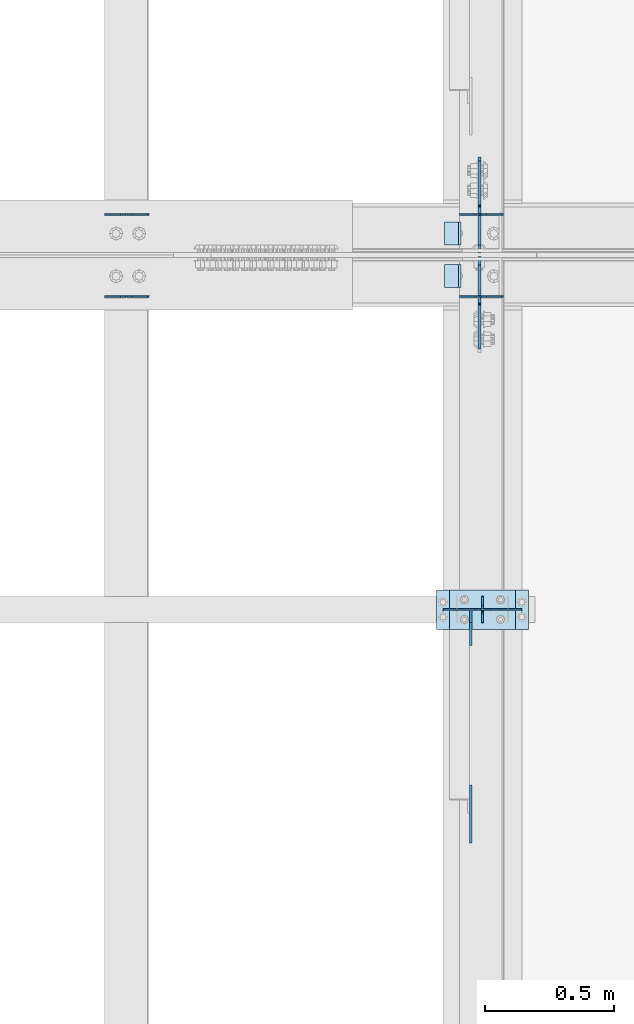
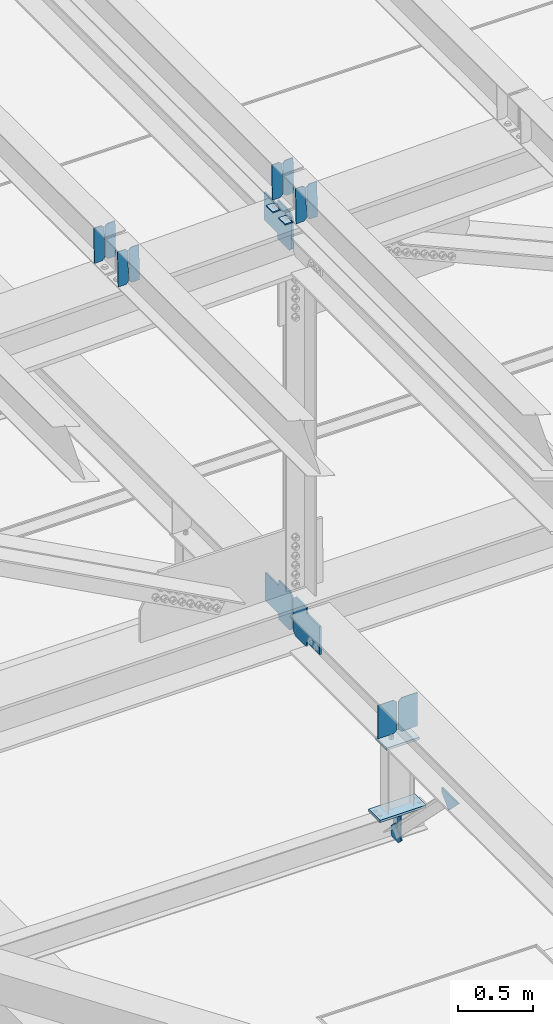
# One storey, part 3239 of 3843: 21 plates, 9 elements without a shape of their own.
"""IFC2X3 building model written with IfcOpenShell, lengths in millimetres."""

from ifc_helpers import new_model, si_unit, frame, origin_with_axes, place, context, subcontext, project, spatial, faceted_brep, material, type_object, element, aggregate, save


model = new_model("IFC2X3")

# Units and contexts
model_context = context("Model", 3, precision=1e-05, world=origin_with_axes())
body_context = subcontext(model_context, "Body", "Model", "MODEL_VIEW")
ifc_project = project(units=[si_unit("LENGTHUNIT", "METRE", prefix="MILLI"), si_unit("AREAUNIT", "SQUARE_METRE"), si_unit("VOLUMEUNIT", "CUBIC_METRE"), si_unit("MASSUNIT", "GRAM", prefix="KILO"), si_unit("TIMEUNIT", "SECOND"), si_unit("PLANEANGLEUNIT", "RADIAN"), si_unit("SOLIDANGLEUNIT", "STERADIAN"), si_unit("THERMODYNAMICTEMPERATUREUNIT", "DEGREE_CELSIUS"), si_unit("LUMINOUSINTENSITYUNIT", "LUMEN")], contexts=[model_context])

# Site, building, storey
site_placement = place(None, origin_with_axes())
site = spatial("IfcSite", under=ifc_project, at=site_placement, CompositionType="ELEMENT")
building_placement = place(site_placement, origin_with_axes())
building = spatial("IfcBuilding", under=site, at=building_placement, Name="Undefined", CompositionType="ELEMENT")
storey_placement = place(building_placement, origin_with_axes())
storey = spatial("IfcBuildingStorey", under=building, at=storey_placement, Name="Undefined", CompositionType="ELEMENT", Elevation=0.0)

# Assembly, plates
assembly_1_placement = place(storey_placement, origin_with_axes())
assembly_1 = element("IfcElementAssembly", 1, at=assembly_1_placement, inside=storey, Name="BEAM", AssemblyPlace="NOTDEFINED", PredefinedType="RIGID_FRAME")
ifc_material = material(Name="STEEL/A572-50")
plate_type_1 = type_object("IfcPlateType", PredefinedType="NOTDEFINED")
plate_1_placement = place(assembly_1_placement, frame((42144.6964783411, 42357.8352138317, 45573.5122364261), z_axis=(-0.021152098061597, -0.00053725799998938, 0.999776124990707), x_axis=(-0.999776269355722, 1.23390000256453e-05, -0.0211520940075457)))
plate_1 = element("IfcPlate", 2, at=plate_1_placement, type_object=plate_type_1, material=ifc_material, Name="PLATE", context=body_context, shape_type="Brep", body=[
    faceted_brep([(0.0, -3.17499999999927, 0.0), (6.83940015733242e-10, -3.17499999996653, 288.924999998613), (6.54836185276508e-10, 3.17500000001746, 288.924999998591), (0.0, 3.17499999999927, 0.0), (60.3250007643655, -3.17500000017753, 288.924999998606), (60.3250007643219, 3.17499999979918, 288.924999998584), (79.3750000013097, -3.17500000025029, 269.875000761494), (79.375000001266, 3.17499999972642, 269.875000761487), (79.375000000713, -3.17500000026484, 19.0499992370605), (79.3750000006985, 3.17499999971187, 19.0499992370533), (60.325000763667, -3.17500000020664, -1.45519152283669e-11), (60.3250007636234, 3.17499999977736, -3.63797880709171e-11)], [[[0, 1, 2, 3]], [[1, 4, 5, 2]], [[4, 6, 7, 5]], [[6, 8, 9, 7]], [[8, 10, 11, 9]], [[10, 0, 3, 11]], [[5, 7, 9, 11, 3, 2]], [[10, 8, 6, 4, 1, 0]]]),
])
plate_2_placement = place(assembly_1_placement, frame((42058.9906576515, 42357.8361882393, 45571.6989730871), z_axis=(-0.021152098061597, -0.00053725799998938, 0.999776124990707), x_axis=(-0.999776269355722, 1.23390000256453e-05, -0.0211520940075457)))
plate_2 = element("IfcPlate", 3, at=plate_2_placement, type_object=plate_type_1, material=ifc_material, Name="PLATE", context=body_context, shape_type="Brep", body=[
    faceted_brep([(4.36557456851006e-11, -3.17499999998836, 19.0499992370969), (6.11180439591408e-10, -3.17499999996653, 269.875000761516), (5.96628524363041e-10, 3.17500000001746, 269.875000761502), (1.45519152283669e-11, 3.17499999998836, 19.0499992370824), (19.0499992376572, -3.17500000003201, 288.924999998606), (19.0499992376281, 3.1749999999447, 288.924999998584), (79.3750000013242, -3.17500000025029, 288.924999998591), (79.3750000013097, 3.1749999997337, 288.92499999857), (79.3750000006548, -3.17500000026484, -2.18278728425503e-11), (79.3750000006403, 3.17499999969732, -2.91038304567337e-11), (19.0499992370023, -3.17500000005384, 0.0), (19.0499992369587, 3.17499999992287, -1.45519152283669e-11)], [[[0, 1, 2, 3]], [[1, 4, 5, 2]], [[4, 6, 7, 5]], [[6, 8, 9, 7]], [[8, 10, 11, 9]], [[10, 0, 3, 11]], [[5, 7, 9, 11, 3, 2]], [[10, 8, 6, 4, 1, 0]]]),
])

assembly_2_placement = place(storey_placement, origin_with_axes())
assembly_2 = element("IfcElementAssembly", 4, at=assembly_2_placement, inside=storey, Name="BEAM", AssemblyPlace="NOTDEFINED", PredefinedType="RIGID_FRAME")
plate_3_placement = place(assembly_2_placement, frame((42144.6964783497, 42041.0140349035, 45572.9760677452), z_axis=(-0.0211520984707749, -0.0028085760011163, 0.999772324397474), x_axis=(-0.999776269337437, 5.94210000636336e-05, -0.0211520150071355)))
plate_3 = element("IfcPlate", 5, at=plate_3_placement, type_object=plate_type_1, material=ifc_material, Name="PLATE", context=body_context, shape_type="Brep", body=[
    faceted_brep([(0.0, -3.17499999999927, 0.0), (6.83940015733242e-10, -3.17499999996653, 288.924999998613), (6.54836185276508e-10, 3.17500000001746, 288.924999998591), (0.0, 3.17499999999927, 0.0), (60.3250007643655, -3.17500000017753, 288.924999998606), (60.3250007643219, 3.17499999979918, 288.924999998584), (79.3750000013097, -3.17500000025029, 269.875000761494), (79.375000001266, 3.17499999972642, 269.875000761487), (79.375000000713, -3.17500000026484, 19.0499992370605), (79.3750000006985, 3.17499999971187, 19.0499992370533), (60.325000763667, -3.17500000020664, -1.45519152283669e-11), (60.3250007636234, 3.17499999977736, -3.63797880709171e-11)], [[[0, 1, 2, 3]], [[1, 4, 5, 2]], [[4, 6, 7, 5]], [[6, 8, 9, 7]], [[8, 10, 11, 9]], [[10, 0, 3, 11]], [[5, 7, 9, 11, 3, 2]], [[10, 8, 6, 4, 1, 0]]]),
])
plate_4_placement = place(assembly_2_placement, frame((42058.99065766, 42041.0191287313, 45571.1628112982), z_axis=(-0.0211520984707749, -0.0028085760011163, 0.999772324397474), x_axis=(-0.999776269337437, 5.94210000636336e-05, -0.0211520150071355)))
plate_4 = element("IfcPlate", 6, at=plate_4_placement, type_object=plate_type_1, material=ifc_material, Name="PLATE", context=body_context, shape_type="Brep", body=[
    faceted_brep([(4.36557456851006e-11, -3.17499999998836, 19.0499992370969), (6.11180439591408e-10, -3.17499999996653, 269.875000761516), (5.96628524363041e-10, 3.17500000001746, 269.875000761502), (1.45519152283669e-11, 3.17499999998836, 19.0499992370824), (19.0499992376572, -3.17500000003201, 288.924999998606), (19.0499992376281, 3.1749999999447, 288.924999998584), (79.3750000013242, -3.17500000025029, 288.924999998591), (79.3750000013097, 3.1749999997337, 288.92499999857), (79.3750000006548, -3.17500000026484, -2.18278728425503e-11), (79.3750000006403, 3.17499999969732, -2.91038304567337e-11), (19.0499992370023, -3.17500000005384, 0.0), (19.0499992369587, 3.17499999992287, -1.45519152283669e-11)], [[[0, 1, 2, 3]], [[1, 4, 5, 2]], [[4, 6, 7, 5]], [[6, 8, 9, 7]], [[8, 10, 11, 9]], [[10, 0, 3, 11]], [[5, 7, 9, 11, 3, 2]], [[10, 8, 6, 4, 1, 0]]]),
])

assembly_3_placement = place(storey_placement, origin_with_axes())
assembly_3 = element("IfcElementAssembly", 7, at=assembly_3_placement, inside=storey, Name="BEAM", AssemblyPlace="NOTDEFINED", PredefinedType="RIGID_FRAME")
plate_5_placement = place(assembly_3_placement, frame((40773.0964781317, 42357.7972526843, 45538.4179024634), z_axis=(-0.0211520977851178, -0.000409932000133268, 0.999776185311015), x_axis=(-0.999776269351943, 8.67199997865676e-06, -0.0211520960074328)))
plate_5 = element("IfcPlate", 8, at=plate_5_placement, type_object=plate_type_1, material=ifc_material, Name="PLATE", context=body_context, shape_type="Brep", body=[
    faceted_brep([(0.0, -3.17499999999927, 0.0), (6.83940015733242e-10, -3.17499999996653, 288.924999998613), (6.54836185276508e-10, 3.17500000001746, 288.924999998591), (0.0, 3.17499999999927, 0.0), (60.3250007643655, -3.17500000017753, 288.924999998606), (60.3250007643219, 3.17499999979918, 288.924999998584), (79.3750000013097, -3.17500000025029, 269.875000761494), (79.375000001266, 3.17499999972642, 269.875000761487), (79.375000000713, -3.17500000026484, 19.0499992370605), (79.3750000006985, 3.17499999971187, 19.0499992370533), (60.325000763667, -3.17500000020664, -1.45519152283669e-11), (60.3250007636234, 3.17499999977736, -3.63797880709171e-11)], [[[0, 1, 2, 3]], [[1, 4, 5, 2]], [[4, 6, 7, 5]], [[6, 8, 9, 7]], [[8, 10, 11, 9]], [[10, 0, 3, 11]], [[5, 7, 9, 11, 3, 2]], [[10, 8, 6, 4, 1, 0]]]),
])
plate_6_placement = place(assembly_3_placement, frame((40687.390657442, 42357.7979960781, 45536.6046390142), z_axis=(-0.0211520977851178, -0.000409932000133268, 0.999776185311015), x_axis=(-0.999776269351943, 8.67199997865676e-06, -0.0211520960074328)))
plate_6 = element("IfcPlate", 9, at=plate_6_placement, type_object=plate_type_1, material=ifc_material, Name="PLATE", context=body_context, shape_type="Brep", body=[
    faceted_brep([(4.36557456851006e-11, -3.17499999998836, 19.0499992370969), (6.11180439591408e-10, -3.17499999996653, 269.875000761516), (5.96628524363041e-10, 3.17500000001746, 269.875000761502), (1.45519152283669e-11, 3.17499999998836, 19.0499992370824), (19.0499992376572, -3.17500000003201, 288.924999998606), (19.0499992376281, 3.1749999999447, 288.924999998584), (79.3750000013242, -3.17500000025029, 288.924999998591), (79.3750000013097, 3.1749999997337, 288.92499999857), (79.3750000006548, -3.17500000026484, -2.18278728425503e-11), (79.3750000006403, 3.17499999969732, -2.91038304567337e-11), (19.0499992370023, -3.17500000005384, 0.0), (19.0499992369587, 3.17499999992287, -1.45519152283669e-11)], [[[0, 1, 2, 3]], [[1, 4, 5, 2]], [[4, 6, 7, 5]], [[6, 8, 9, 7]], [[8, 10, 11, 9]], [[10, 0, 3, 11]], [[5, 7, 9, 11, 3, 2]], [[10, 8, 6, 4, 1, 0]]]),
])
aggregate(assembly_3, [plate_5, plate_6])

assembly_4_placement = place(storey_placement, origin_with_axes())
assembly_4 = element("IfcElementAssembly", 10, at=assembly_4_placement, inside=storey, Name="BEAM", AssemblyPlace="NOTDEFINED", PredefinedType="RIGID_FRAME")
plate_7_placement = place(assembly_4_placement, frame((40773.0964782747, 42040.82102682, 45538.0051295688), z_axis=(-0.0211520975230524, -0.00216324900001201, 0.999773929008023), x_axis=(-0.999776269348977, 4.5491000049241e-05, -0.0211520490073722)))
plate_7 = element("IfcPlate", 11, at=plate_7_placement, type_object=plate_type_1, material=ifc_material, Name="PLATE", context=body_context, shape_type="Brep", body=[
    faceted_brep([(0.0, -3.17499999999927, 0.0), (6.83940015733242e-10, -3.17499999996653, 288.924999998613), (6.54836185276508e-10, 3.17500000001746, 288.924999998591), (0.0, 3.17499999999927, 0.0), (60.3250007643655, -3.17500000017753, 288.924999998606), (60.3250007643219, 3.17499999979918, 288.924999998584), (79.3750000013097, -3.17500000025029, 269.875000761494), (79.375000001266, 3.17499999972642, 269.875000761487), (79.375000000713, -3.17500000026484, 19.0499992370605), (79.3750000006985, 3.17499999971187, 19.0499992370533), (60.325000763667, -3.17500000020664, -1.45519152283669e-11), (60.3250007636234, 3.17499999977736, -3.63797880709171e-11)], [[[0, 1, 2, 3]], [[1, 4, 5, 2]], [[4, 6, 7, 5]], [[6, 8, 9, 7]], [[8, 10, 11, 9]], [[10, 0, 3, 11]], [[5, 7, 9, 11, 3, 2]], [[10, 8, 6, 4, 1, 0]]]),
])
plate_8_placement = place(assembly_4_placement, frame((40687.3906575854, 42040.8249502391, 45536.191870212), z_axis=(-0.0211520975230524, -0.00216324900001201, 0.999773929008023), x_axis=(-0.999776269348977, 4.5491000049241e-05, -0.0211520490073722)))
plate_8 = element("IfcPlate", 12, at=plate_8_placement, type_object=plate_type_1, material=ifc_material, Name="PLATE", context=body_context, shape_type="Brep", body=[
    faceted_brep([(4.36557456851006e-11, -3.17499999998836, 19.0499992370969), (6.11180439591408e-10, -3.17499999996653, 269.875000761516), (5.96628524363041e-10, 3.17500000001746, 269.875000761502), (1.45519152283669e-11, 3.17499999998836, 19.0499992370824), (19.0499992376572, -3.17500000003201, 288.924999998606), (19.0499992376281, 3.1749999999447, 288.924999998584), (79.3750000013242, -3.17500000025029, 288.924999998591), (79.3750000013097, 3.1749999997337, 288.92499999857), (79.3750000006548, -3.17500000026484, -2.18278728425503e-11), (79.3750000006403, 3.17499999969732, -2.91038304567337e-11), (19.0499992370023, -3.17500000005384, 0.0), (19.0499992369587, 3.17499999992287, -1.45519152283669e-11)], [[[0, 1, 2, 3]], [[1, 4, 5, 2]], [[4, 6, 7, 5]], [[6, 8, 9, 7]], [[8, 10, 11, 9]], [[10, 0, 3, 11]], [[5, 7, 9, 11, 3, 2]], [[10, 8, 6, 4, 1, 0]]]),
])
aggregate(assembly_4, [plate_7, plate_8])

assembly_5_placement = place(storey_placement, origin_with_axes())
assembly_5 = element("IfcElementAssembly", 13, at=assembly_5_placement, inside=storey, Name="BEAM", AssemblyPlace="NOTDEFINED", PredefinedType="RIGID_FRAME")
plate_type_2 = type_object("IfcPlateType", PredefinedType="NOTDEFINED")
plate_9_placement = place(assembly_5_placement, frame((42062.4, 40779.7, 41495.6625), z_axis=(0.0, 0.0, -1.0), x_axis=(0.0, 1.0, 0.0)))
plate_9 = element("IfcPlate", 14, at=plate_9_placement, type_object=plate_type_2, material=ifc_material, Name="PLATE", context=body_context, shape_type="Brep", body=[
    faceted_brep([(0.0, -3.17499999999927, 0.0), (0.0, -3.17500000000291, 187.324999999997), (0.0, 3.17500000000291, 187.324999999997), (0.0, 3.17499999999927, 0.0), (34.9250001907349, -3.17500000000291, 187.324999999997), (34.9250001907349, 3.17500000000291, 187.324999999997), (47.625, -3.17500000000291, 174.625000190732), (47.625, 3.17500000000291, 174.625000190732), (47.625, -3.17499999999927, 12.6999998092651), (47.625, 3.17499999999927, 12.6999998092651), (34.9250001907349, -3.17499999999927, 0.0), (34.9250001907349, 3.17499999999927, 0.0)], [[[0, 1, 2, 3]], [[1, 4, 5, 2]], [[4, 6, 7, 5]], [[6, 8, 9, 7]], [[8, 10, 11, 9]], [[10, 0, 3, 11]], [[5, 7, 9, 11, 3, 2]], [[10, 8, 6, 4, 1, 0]]]),
])
plate_10_placement = place(assembly_5_placement, frame((42062.4, 40881.3, 41495.6625), z_axis=(0.0, 0.0, -1.0), x_axis=(0.0, -1.0, 0.0)))
plate_10 = element("IfcPlate", 15, at=plate_10_placement, type_object=plate_type_2, material=ifc_material, Name="PLATE", context=body_context, shape_type="Brep", body=[
    faceted_brep([(0.0, -3.17499999999927, 0.0), (0.0, -3.17500000000291, 187.324999999997), (0.0, 3.17500000000291, 187.324999999997), (0.0, 3.17499999999927, 0.0), (34.9250001907349, -3.17500000000291, 187.324999999997), (34.9250001907349, 3.17500000000291, 187.324999999997), (47.625, -3.17500000000291, 174.625000190732), (47.625, 3.17500000000291, 174.625000190732), (47.625, -3.17499999999927, 12.6999998092651), (47.625, 3.17499999999927, 12.6999998092651), (34.9250001907349, -3.17499999999927, 0.0), (34.9250001907349, 3.17499999999927, 0.0)], [[[0, 1, 2, 3]], [[1, 4, 5, 2]], [[4, 6, 7, 5]], [[6, 8, 9, 7]], [[8, 10, 11, 9]], [[10, 0, 3, 11]], [[5, 7, 9, 11, 3, 2]], [[10, 8, 6, 4, 1, 0]]]),
])

# Plate
plate_type_3 = type_object("IfcPlateType", PredefinedType="NOTDEFINED")
plate_11_placement = place(assembly_1_placement, frame((41979.7677316307, 42329.1, 45563.5877778858), z_axis=(0.0, -1.0, 0.0), x_axis=(-0.999776270257024, 0.0, -0.0211520550054595)))
plate_11 = element("IfcPlate", 16, at=plate_11_placement, type_object=plate_type_3, material=ifc_material, Name="PLATE", context=body_context, shape_type="Brep", body=[
    faceted_brep([(9.52499999982683, -4.7625000001135, 88.8999999999942), (0.0, 4.76249999999709, 88.9000015258789), (0.0, 4.76249999999709, 0.0), (9.52499999981956, -4.76249999999709, 0.0), (63.4999984608512, -4.76249999988795, 88.8999999999796), (63.4999984608367, -4.76249999988795, -1.45519152283669e-11), (63.4999984608221, 4.76250000013533, -1.45519152283669e-11), (63.4999984608367, 4.76250000013533, 88.8999999999796)], [[[0, 1, 2, 3]], [[4, 5, 6, 7]], [[5, 4, 0, 3]], [[6, 5, 3, 2]], [[7, 6, 2, 1]], [[4, 7, 1, 0]]]),
])

aggregate(assembly_1, [plate_1, plate_2, plate_11])

plate_12_placement = place(assembly_2_placement, frame((41979.7677316307, 42164.0000015258, 45563.5877778858), z_axis=(0.0, -1.0, 0.0), x_axis=(-0.999776270257024, 0.0, -0.0211520550054595)))
plate_12 = element("IfcPlate", 17, at=plate_12_placement, type_object=plate_type_3, material=ifc_material, Name="PLATE", context=body_context, shape_type="Brep", body=[
    faceted_brep([(9.52499999982683, -4.7625000001135, 88.8999999999942), (0.0, 4.76249999999709, 88.9000015258789), (0.0, 4.76249999999709, 0.0), (9.52499999981956, -4.76249999999709, 0.0), (63.4999984608512, -4.76249999988795, 88.8999999999796), (63.4999984608367, -4.76249999988795, -1.45519152283669e-11), (63.4999984608221, 4.76250000013533, -1.45519152283669e-11), (63.4999984608367, 4.76250000013533, 88.8999999999796)], [[[0, 1, 2, 3]], [[4, 5, 6, 7]], [[5, 4, 0, 3]], [[6, 5, 3, 2]], [[7, 6, 2, 1]], [[4, 7, 1, 0]]]),
])

aggregate(assembly_2, [plate_3, plate_4, plate_12])

# Assembly, plates
assembly_6_placement = place(storey_placement, origin_with_axes())
assembly_6 = element("IfcElementAssembly", 18, at=assembly_6_placement, inside=storey, Name="BEAM", AssemblyPlace="NOTDEFINED", PredefinedType="RIGID_FRAME")
plate_type_4 = type_object("IfcPlateType", PredefinedType="NOTDEFINED")
plate_13_placement = place(assembly_6_placement, frame((42051.2874999444, 42209.24375, 42145.6402974488), z_axis=(0.0, 0.707106781186548, 0.707106781186548), x_axis=(5.70000238222118e-08, 0.707106781186546, -0.707106781186546)))
plate_13 = element("IfcPlate", 19, at=plate_13_placement, type_object=plate_type_4, material=ifc_material, Name="PLATE", context=body_context, shape_type="Brep", body=[
    faceted_brep([(0.0, -6.3499999046162, 0.0), (-179.568557372404, -6.34999999999854, 179.568557372371), (-179.568557372404, 6.34999999999854, 179.568557372371), (7.27595761418343e-12, 6.3499999046162, 0.0), (-179.568557371938, -6.34999999999854, 224.469837977951), (-179.568557371938, 6.34999999999854, 224.469837977951), (-75.7343459937983, -6.34999999999854, 328.304049356128), (-75.7343459937983, 6.34999999999854, 328.304049356128), (-53.4273871011683, -6.34999999999854, 305.997090463476), (-53.4273871011683, 6.34999999999854, 305.997090463476), (-49.3072106330073, -6.34999999999854, 303.244076563016), (-49.3072106330073, 6.34999999999854, 303.244076563016), (-44.4471311149682, -6.34999999999854, 302.277346640451), (-44.4471311149682, 6.34999999999854, 302.277346640451), (-39.5870515968854, -6.34999999999854, 303.244076563064), (-39.5870515968854, 6.34999999999854, 303.244076563064), (-35.4668751287099, -6.34999999999854, 305.99709046357), (-35.4668751287099, 6.34999999999854, 305.99709046357), (81.2764546052931, -6.34999999999854, 422.74042019761), (81.2764546052931, 6.34999999999854, 422.74042019761), (242.921064783775, -6.34999999999854, 261.095810019164), (242.921064783775, 6.34999999999854, 261.095810019164), (126.177735049772, -6.34999999999854, 144.352480285124), (126.177735049772, 6.34999999999854, 144.352480285124), (123.424721149277, -6.34999999999854, 140.232303816942), (123.424721149277, 6.34999999999854, 140.232303816942), (122.457991226664, -6.34999999999854, 135.372224298895), (122.457991226664, 6.34999999999854, 135.372224298895), (123.424721149218, -6.34999999999854, 130.512144780827), (123.424721149218, 6.34999999999854, 130.512144780827), (126.177735049685, -6.34999999999854, 126.391968312688), (126.177735049685, 6.34999999999854, 126.391968312688), (148.735492004496, -6.35000000000582, 103.834211399357), (148.735492004496, 6.35000000000582, 103.834211399357), (44.9012806051323, -6.35000000000582, -1.45519152283669e-11), (44.9012806051323, 6.35000000000582, -1.45519152283669e-11)], [[[0, 1, 2, 3]], [[1, 4, 5, 2]], [[4, 6, 7, 5]], [[6, 8, 9, 7]], [[8, 10, 11, 9]], [[10, 12, 13, 11]], [[12, 14, 15, 13]], [[14, 16, 17, 15]], [[16, 18, 19, 17]], [[18, 20, 21, 19]], [[20, 22, 23, 21]], [[22, 24, 25, 23]], [[24, 26, 27, 25]], [[26, 28, 29, 27]], [[28, 30, 31, 29]], [[30, 32, 33, 31]], [[32, 34, 35, 33]], [[34, 0, 3, 35]], [[5, 7, 9, 11, 13, 15, 17, 19, 21, 23, 25, 27, 29, 31, 33, 35, 3, 2]], [[34, 32, 30, 28, 26, 24, 22, 20, 18, 16, 14, 12, 10, 8, 6, 4, 1, 0]]]),
])
plate_14_placement = place(assembly_6_placement, frame((42051.2875706001, 42194.9562499787, 42145.6402977713), z_axis=(0.0, -0.707106781186682, 0.707106781186413), x_axis=(0.0, -0.707106781186548, -0.707106781186548)))
plate_14 = element("IfcPlate", 20, at=plate_14_placement, type_object=plate_type_4, material=ifc_material, Name="PLATE", context=body_context, shape_type="Brep", body=[
    faceted_brep([(0.0, -6.3499999046162, 0.0), (-179.568557372404, -6.34999999999854, 179.568557372371), (-179.568557372404, 6.34999999999854, 179.568557372371), (7.27595761418343e-12, 6.3499999046162, 0.0), (-179.568557371938, -6.34999999999854, 224.469837977951), (-179.568557371938, 6.34999999999854, 224.469837977951), (-75.7343459937983, -6.34999999999854, 328.304049356128), (-75.7343459937983, 6.34999999999854, 328.304049356128), (-52.8534562967398, -6.34999999999854, 305.423159705722), (-52.8534562967398, 6.34999999999854, 305.423159705722), (-48.7332798285934, -6.34999999999854, 302.670145805241), (-48.7332798285934, 6.34999999999854, 302.670145805241), (-43.8732003105324, -6.34999999999854, 301.703415882701), (-43.8732003105324, 6.34999999999854, 301.703415882701), (-39.0131207924715, -6.34999999999854, 302.670145805299), (-39.0131207924715, 6.34999999999854, 302.670145805299), (-34.8929443242996, -6.34999999999854, 305.42315970581), (-34.8929443242996, 6.34999999999854, 305.42315970581), (81.8503853864022, -6.34999999999854, 422.166489416515), (81.8503853864022, 6.34999999999854, 422.166489416515), (243.494995564877, -6.34999999999854, 260.521879238091), (243.494995564877, 6.34999999999854, 260.521879238091), (126.751665854183, -6.34999999999854, 143.778549527357), (126.751665854183, 6.34999999999854, 143.778549527357), (123.998651953683, -6.34999999999854, 139.658373059181), (123.998651953683, 6.34999999999854, 139.658373059181), (123.031922031063, -6.34999999999854, 134.798293541113), (123.031922031063, 6.34999999999854, 134.798293541113), (123.998651953632, -6.34999999999854, 129.938214023059), (123.998651953632, 6.34999999999854, 129.938214023059), (126.751665854099, -6.34999999999854, 125.818037554913), (126.751665854099, 6.34999999999854, 125.818037554913), (148.735492004496, -6.35000000000582, 103.834211399357), (148.735492004496, 6.35000000000582, 103.834211399357), (44.9012806051323, -6.35000000000582, -1.45519152283669e-11), (44.9012806051323, 6.35000000000582, -1.45519152283669e-11)], [[[0, 1, 2, 3]], [[1, 4, 5, 2]], [[4, 6, 7, 5]], [[6, 8, 9, 7]], [[8, 10, 11, 9]], [[10, 12, 13, 11]], [[12, 14, 15, 13]], [[14, 16, 17, 15]], [[16, 18, 19, 17]], [[18, 20, 21, 19]], [[20, 22, 23, 21]], [[22, 24, 25, 23]], [[24, 26, 27, 25]], [[26, 28, 29, 27]], [[28, 30, 31, 29]], [[30, 32, 33, 31]], [[32, 34, 35, 33]], [[34, 0, 3, 35]], [[5, 7, 9, 11, 13, 15, 17, 19, 21, 23, 25, 27, 29, 31, 33, 35, 3, 2]], [[34, 32, 30, 28, 26, 24, 22, 20, 18, 16, 14, 12, 10, 8, 6, 4, 1, 0]]]),
])
aggregate(assembly_6, [plate_13, plate_14])

# Assembly, plate
assembly_7_placement = place(storey_placement, origin_with_axes())
assembly_7 = element("IfcElementAssembly", 21, at=assembly_7_placement, inside=storey, Name="BEAM", AssemblyPlace="NOTDEFINED", PredefinedType="RIGID_FRAME")
plate_15_placement = place(assembly_7_placement, frame((42051.2874998798, 42213.2125, 45236.4847886337), z_axis=(0.0, 0.707106781186548, 0.707106781186548), x_axis=(5.70000238222118e-08, 0.707106781186546, -0.707106781186546)))
plate_15 = element("IfcPlate", 22, at=plate_15_placement, type_object=plate_type_4, material=ifc_material, Name="PLATE", context=body_context, shape_type="Brep", body=[
    faceted_brep([(0.0, -6.3499999046162, 0.0), (-179.450181359635, -6.34999999999854, 179.450181359643), (-179.450181359635, 6.34999999999854, 179.450181359643), (7.27595761418343e-12, 6.3499999046162, 0.0), (-179.450181359639, -6.34999999999854, 224.351461964776), (-179.450181359639, 6.34999999999854, 224.351461964776), (-68.3195118619651, -6.34999999999854, 335.482131462442), (-68.3195118619651, 6.34999999999854, 335.482131462442), (-46.2443512096934, -6.34999999999854, 313.406970810174), (-46.2443512096934, 6.34999999999854, 313.406970810174), (-42.1241747415397, -6.34999999999854, 310.6539569097), (-42.1241747415397, 6.34999999999854, 310.6539569097), (-37.2640952235151, -6.34999999999854, 309.687226987116), (-37.2640952235151, 6.34999999999854, 309.687226987116), (-32.404015705476, -6.34999999999854, 310.6539569097), (-32.404015705476, 6.34999999999854, 310.6539569097), (-28.2838392373369, -6.34999999999854, 313.406970810174), (-28.2838392373369, 6.34999999999854, 313.406970810174), (88.459490470862, -6.34999999999854, 430.150300518377), (88.459490470862, 6.34999999999854, 430.150300518377), (250.10410064933, -6.34999999999854, 268.505690339909), (250.10410064933, 6.34999999999854, 268.505690339909), (133.360770941131, -6.34999999999854, 151.762360631707), (133.360770941131, 6.34999999999854, 151.762360631707), (130.607757040661, -6.34999999999854, 147.64218416356), (130.607757040661, 6.34999999999854, 147.64218416356), (129.641027118069, -6.34999999999854, 142.782104645536), (129.641027118069, 6.34999999999854, 142.782104645536), (130.607757040661, -6.34999999999854, 137.922025127496), (130.607757040661, 6.34999999999854, 137.922025127496), (133.360770941127, -6.34999999999854, 133.80184865935), (133.360770941127, 6.34999999999854, 133.80184865935), (156.031950102829, -6.35000000000582, 111.130669497703), (156.031950102829, 6.35000000000582, 111.130669497703), (44.9012806051323, -6.35000000000582, -1.45519152283669e-11), (44.9012806051323, 6.35000000000582, -1.45519152283669e-11)], [[[0, 1, 2, 3]], [[1, 4, 5, 2]], [[4, 6, 7, 5]], [[6, 8, 9, 7]], [[8, 10, 11, 9]], [[10, 12, 13, 11]], [[12, 14, 15, 13]], [[14, 16, 17, 15]], [[16, 18, 19, 17]], [[18, 20, 21, 19]], [[20, 22, 23, 21]], [[22, 24, 25, 23]], [[24, 26, 27, 25]], [[26, 28, 29, 27]], [[28, 30, 31, 29]], [[30, 32, 33, 31]], [[32, 34, 35, 33]], [[34, 0, 3, 35]], [[5, 7, 9, 11, 13, 15, 17, 19, 21, 23, 25, 27, 29, 31, 33, 35, 3, 2]], [[34, 32, 30, 28, 26, 24, 22, 20, 18, 16, 14, 12, 10, 8, 6, 4, 1, 0]]]),
])
aggregate(assembly_7, [plate_15])

# Assembly, plates
assembly_8_placement = place(storey_placement, origin_with_axes())
assembly_8 = element("IfcElementAssembly", 23, at=assembly_8_placement, inside=storey, Name="POST", AssemblyPlace="NOTDEFINED", PredefinedType="RIGID_FRAME")
plate_type_5 = type_object("IfcPlateType", PredefinedType="NOTDEFINED")
plate_16_placement = place(assembly_8_placement, frame((41935.3999969428, 40906.6996995978, 42083.0375), z_axis=(0.0, -1.0, 0.0), x_axis=(1.0, 0.0, 0.0)))
plate_16 = element("IfcPlate", 24, at=plate_16_placement, type_object=plate_type_5, material=ifc_material, Name="PLATE", context=body_context, shape_type="Brep", body=[
    faceted_brep([(0.0, -9.52500000000146, 0.0), (0.0, -9.5249999999287, 152.40000000162), (0.0, 9.52500000002328, 152.40000000162), (0.0, 9.52500000000146, 0.0), (254.0, -9.5249999999287, 152.40000000162), (254.0, 9.52500000002328, 152.40000000162), (253.999999999998, -9.52500000000146, 0.0), (253.999999999998, 9.52500000000146, 0.0)], [[[0, 1, 2, 3]], [[1, 4, 5, 2]], [[4, 6, 7, 5]], [[6, 0, 3, 7]], [[5, 7, 3, 2]], [[6, 4, 1, 0]]]),
])
plate_17_placement = place(assembly_8_placement, frame((42240.2, 40754.3, 41513.125), z_axis=(-1.0, 0.0, 0.0), x_axis=(0.0, 1.0, 0.0)))
plate_17 = element("IfcPlate", 25, at=plate_17_placement, type_object=plate_type_5, material=ifc_material, Name="PLATE", context=body_context, shape_type="Brep", body=[
    faceted_brep([(0.0, -9.52500000000146, 0.0), (0.0, -9.52500000000146, 355.599999999999), (0.0, 9.52500000000146, 355.599999999999), (0.0, 9.52500000000146, 0.0), (152.399999999994, -9.52500000000146, 355.599999999999), (152.399999999994, 9.52500000000146, 355.599999999999), (152.400000000001, -9.52500000000146, 0.0), (152.400000000001, 9.52500000000146, 0.0)], [[[0, 1, 2, 3]], [[1, 4, 5, 2]], [[4, 6, 7, 5]], [[6, 0, 3, 7]], [[5, 7, 3, 2]], [[6, 4, 1, 0]]]),
])
aggregate(assembly_8, [plate_16, plate_17])

# Assembly, plate
assembly_9_placement = place(storey_placement, origin_with_axes())
assembly_9 = element("IfcElementAssembly", 26, at=assembly_9_placement, inside=storey, Name="BEAM", AssemblyPlace="NOTDEFINED", PredefinedType="RIGID_FRAME")
plate_type_6 = type_object("IfcPlateType", PredefinedType="NOTDEFINED")
plate_18_placement = place(assembly_9_placement, frame((42016.3625, 39928.4601146785, 42112.5438627551), z_axis=(0.0, 0.707106781186548, 0.707106781186548), x_axis=(5.70000238222118e-08, 0.707106781186546, -0.707106781186546)))
plate_18 = element("IfcPlate", 27, at=plate_18_placement, type_object=plate_type_6, material=ifc_material, Name="PLATE", context=body_context, shape_type="Brep", body=[
    faceted_brep([(0.0, -4.76249999999709, 0.0), (157.726597423803, -4.76249999999709, 157.726601438866), (157.726597423803, 4.76249999999709, 157.726601438866), (0.0, 4.76249999999709, 0.0), (188.387110059113, -4.76249999999709, 127.066089584019), (188.387110059113, 4.76249999999709, 127.066089584019), (188.387111679331, -4.76249999999709, 1.09139364212751e-10), (188.387111679331, 4.76249999999709, 1.09139364212751e-10)], [[[0, 1, 2, 3]], [[1, 4, 5, 2]], [[4, 6, 7, 5]], [[6, 0, 3, 7]], [[5, 7, 3, 2]], [[6, 4, 1, 0]]]),
])

# Plate
plate_type_7 = type_object("IfcPlateType", PredefinedType="NOTDEFINED")
plate_19_placement = place(assembly_5_placement, frame((42016.3625, 40827.3250000347, 41306.750000025), z_axis=(0.0, -1.0, 0.0), x_axis=(0.0, 0.0, 1.0)))
plate_19 = element("IfcPlate", 28, at=plate_19_placement, type_object=plate_type_7, material=ifc_material, Name="PLATE", context=body_context, shape_type="Brep", body=[
    faceted_brep([(0.0, -4.76250000000073, 12.6999998092651), (4.450703272596e-08, -4.76249999999709, 93.0710244828806), (4.450703272596e-08, 4.76249999999709, 93.0710244828806), (0.0, 4.76250000000073, 12.6999998092651), (43.3137807601452, -4.76249999999709, 136.384805065652), (43.3137807601452, 4.76249999999709, 136.384805065652), (133.209805202001, -4.76249999999709, 46.4887805392646), (133.209805202001, 4.76249999999709, 46.4887805392646), (86.7210245267561, -4.76249999999709, 0.0), (86.7210245267561, 4.76249999999709, 0.0), (12.6999998092651, -4.76250000000073, 0.0), (12.6999998092651, 4.76250000000073, 0.0)], [[[0, 1, 2, 3]], [[1, 4, 5, 2]], [[4, 6, 7, 5]], [[6, 8, 9, 7]], [[8, 10, 11, 9]], [[10, 0, 3, 11]], [[5, 7, 9, 11, 3, 2]], [[10, 8, 6, 4, 1, 0]]]),
])

aggregate(assembly_5, [plate_19, plate_9, plate_10])

plate_type_8 = type_object("IfcPlateType", PredefinedType="NOTDEFINED")
plate_20_placement = place(assembly_9_placement, frame((42214.8, 40829.684259493, 42405.3356744657), z_axis=(0.0, 0.00280793599926983, -0.999996057739941), x_axis=(-1.0, 0.0, 0.0)))
plate_20 = element("IfcPlate", 29, at=plate_20_placement, type_object=plate_type_8, material=ifc_material, Name="PLATE", context=body_context, shape_type="Brep", body=[
    faceted_brep([(0.0, -3.17499999999927, 0.0), (0.0, -3.17500000007567, 273.049999997937), (0.0, 3.17499999993743, 273.049999997937), (0.0, 3.17499999999927, 0.0), (122.237500389827, -3.17500000007567, 273.049999997937), (122.237500389827, 3.17499999993743, 273.049999997937), (147.637500008357, -3.17500000006476, 247.650000379464), (147.637500008357, 3.17499999994106, 247.650000379464), (147.637500008357, -3.17500000001382, 25.3999996184648), (147.637500008357, 3.17499999999927, 25.3999996184648), (122.237500389827, -3.17500000000291, 0.0), (122.237500389827, 3.17500000000291, -7.27595761418343e-12)], [[[0, 1, 2, 3]], [[1, 4, 5, 2]], [[4, 6, 7, 5]], [[6, 8, 9, 7]], [[8, 10, 11, 9]], [[10, 0, 3, 11]], [[5, 7, 9, 11, 3, 2]], [[10, 8, 6, 4, 1, 0]]]),
])

plate_21_placement = place(assembly_9_placement, frame((41910.0, 40829.684259493, 42405.3356744657), z_axis=(0.0, 0.00280793599926983, -0.999996057739941), x_axis=(1.0, 0.0, 0.0)))
plate_21 = element("IfcPlate", 30, at=plate_21_placement, type_object=plate_type_8, material=ifc_material, Name="PLATE", context=body_context, shape_type="Brep", body=[
    faceted_brep([(0.0, -3.17499999999927, 0.0), (0.0, -3.17500000007567, 273.049999997937), (0.0, 3.17499999993743, 273.049999997937), (0.0, 3.17499999999927, 0.0), (122.237500389827, -3.17500000007567, 273.049999997937), (122.237500389827, 3.17499999993743, 273.049999997937), (147.637500008357, -3.17500000006476, 247.650000379464), (147.637500008357, 3.17499999994106, 247.650000379464), (147.637500008357, -3.17500000001382, 25.3999996184648), (147.637500008357, 3.17499999999927, 25.3999996184648), (122.237500389827, -3.17500000000291, 0.0), (122.237500389827, 3.17500000000291, -7.27595761418343e-12)], [[[0, 1, 2, 3]], [[1, 4, 5, 2]], [[4, 6, 7, 5]], [[6, 8, 9, 7]], [[8, 10, 11, 9]], [[10, 0, 3, 11]], [[5, 7, 9, 11, 3, 2]], [[10, 8, 6, 4, 1, 0]]]),
])

aggregate(assembly_9, [plate_20, plate_21, plate_18])

save(model, "model.ifc")
